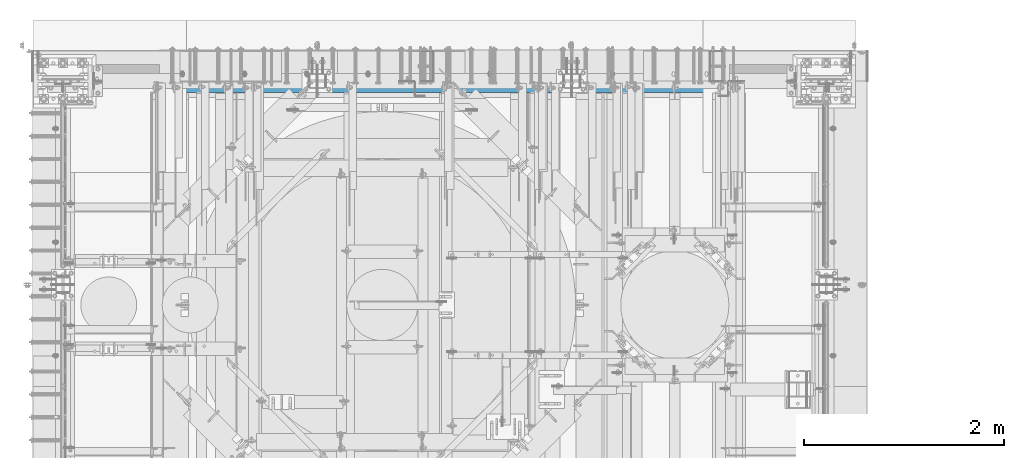
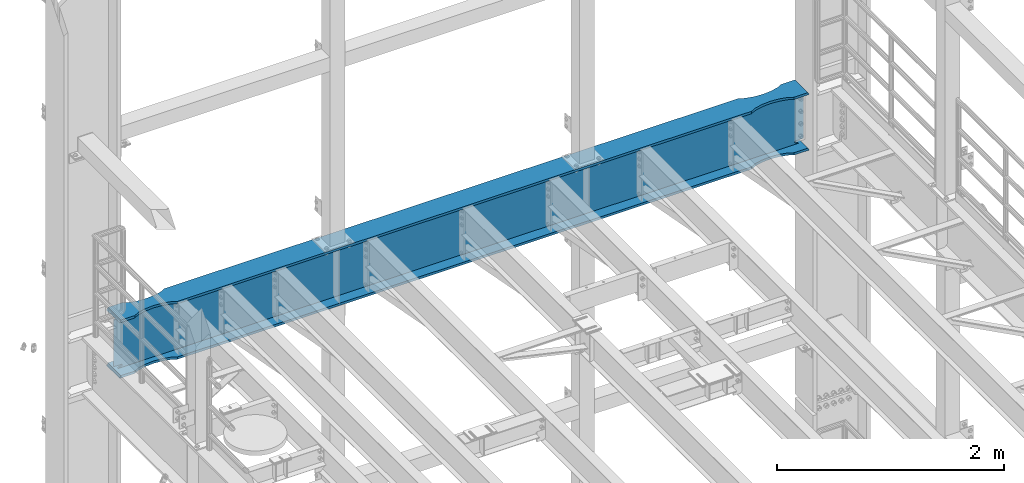
# One storey, part 1065 of 1876: 1 beam, 1 element without a shape of its own.
"""IFC2X3 building model written with IfcOpenShell, lengths in millimetres."""

from ifc_helpers import new_model, si_unit, frame, origin_with_axes, place, context, subcontext, project, spatial, faceted_brep, material, type_object, element, aggregate, save


model = new_model("IFC2X3")

# Units and contexts
model_context = context("Model", 3, precision=1e-05, world=origin_with_axes())
body_context = subcontext(model_context, "Body", "Model", "MODEL_VIEW")
ifc_project = project(units=[si_unit("LENGTHUNIT", "METRE", prefix="MILLI"), si_unit("AREAUNIT", "SQUARE_METRE"), si_unit("VOLUMEUNIT", "CUBIC_METRE"), si_unit("MASSUNIT", "GRAM", prefix="KILO"), si_unit("TIMEUNIT", "SECOND"), si_unit("PLANEANGLEUNIT", "RADIAN"), si_unit("SOLIDANGLEUNIT", "STERADIAN"), si_unit("THERMODYNAMICTEMPERATUREUNIT", "DEGREE_CELSIUS"), si_unit("LUMINOUSINTENSITYUNIT", "LUMEN")], contexts=[model_context])

# Site, building, storey
site_placement = place(None, origin_with_axes())
site = spatial("IfcSite", under=ifc_project, at=site_placement, CompositionType="ELEMENT")
building_placement = place(site_placement, origin_with_axes())
building = spatial("IfcBuilding", under=site, at=building_placement, Name="Undefined", CompositionType="ELEMENT")
storey_placement = place(building_placement, origin_with_axes())
storey = spatial("IfcBuildingStorey", under=building, at=storey_placement, Name="Undefined", CompositionType="ELEMENT", Elevation=0.0)

# Assembly, beam
assembly_placement = place(storey_placement, origin_with_axes())
assembly = element("IfcElementAssembly", 1, at=assembly_placement, inside=storey, Name="BEAM", AssemblyPlace="NOTDEFINED", PredefinedType="RIGID_FRAME")
ifc_material = material(Name="STEEL/A992")
beam_type = type_object("IfcBeamType", Name="W24X103", PredefinedType="NOTDEFINED")
beam_placement = place(assembly_placement, frame((0.0, 13716.0, 17672.05), z_axis=(0.0, 0.0, 1.0), x_axis=(1.0, 0.0, 0.0)))
beam = element("IfcBeam", 2, at=beam_placement, type_object=beam_type, material=ifc_material, Name="BEAM", ObjectType="W24X103", context=body_context, shape_type="Brep", body=[
    faceted_brep([(7310.4375, 7.14374999999927, 250.825000000001), (7318.375, -7.14374999999927, 250.825000000001), (7318.375, -7.14374999999927, -250.825000000001), (7310.4375, 7.14374999999927, -250.825000000001), (301.625, -7.14374999999927, 250.825000000001), (309.5625, 7.14374999999927, 250.825000000001), (309.5625, 7.14374999999927, -250.825000000001), (301.625, -7.14374999999927, -250.825000000001), (7031.26184334843, -69.8863852197028, -285.75), (7031.26184334843, -69.8863852197028, -311.150000000001), (7113.70085269938, -88.8999885500325, -311.150000000001), (7113.70085269938, -88.8999885500325, -285.75), (6946.89999522536, -63.4999969110422, -285.75), (6946.89999522536, -63.4999969110422, -311.150000000001), (6862.53814723751, -69.886387005964, -285.75), (6862.53814723751, -69.886387005964, -311.150000000001), (6780.09913828916, -88.8999920818405, -285.75), (6780.09913828916, -88.8999920818405, -311.150000000001), (6730.99999123786, -114.3, -285.75), (6730.99999123786, -114.3, -311.150000000001), (889.000008761879, -114.300009625518, -285.75), (889.000008761879, -114.3, -311.150000000001), (6730.99999123786, -114.3, 285.75), (6730.99999123786, -114.3, 311.150000000001), (889.000008761879, -114.300009625518, 311.150000000001), (889.000008761879, -114.3, 285.75), (6780.09913828916, -88.8999920818405, 285.75), (6780.09913828916, -88.8999920818405, 311.150000000001), (6862.53814723751, -69.886387005964, 285.75), (6862.53814723751, -69.886387005964, 311.150000000001), (6946.89999522536, -63.4999969110422, 285.75), (6946.89999522536, -63.4999969110422, 311.150000000001), (7031.26184334843, -69.8863852197028, 285.75), (7031.26184334843, -69.8863852197028, 311.150000000001), (7113.70085269938, -88.8999885500325, 285.75), (7113.70085269938, -88.8999885500325, 311.150000000001), (7162.79999999982, -114.299985144468, 311.150000000001), (7162.79999999982, -114.3, 285.75), (7318.375, -114.3, 285.75), (7303.71041369173, -114.299998599709, 311.150000000001), (7269.91500317383, -7.14375000000018, -285.35299987793), (7269.91500317383, 7.14375000000018, -285.35299987793), (7234.44274885072, 7.14375000000018, -269.000062630286), (7234.44274885072, -7.14375000000018, -269.000062630286), (7230.55254094452, 7.14375000000018, -265.703842989446), (7230.55254094452, -7.14375000000018, -265.703842989446), (7228.91987519741, 7.14375000000018, -260.873399528195), (7228.91987519741, -7.14375000000018, -260.873399528195), (7230.01261637614, 7.14375000000018, -255.89296800167), (7230.01261637614, -7.14375000000018, -255.89296800167), (7233.51762316711, 7.14375000000018, -252.189765486371), (7233.51762316711, -7.14375000000018, -252.189765486371), (7238.43048349907, 7.14375000000018, -250.825000000001), (7238.43048349907, -7.14375000000018, -250.825000000001), (7239.26548546451, 7.14375000000018, 250.825000000001), (7239.26548546451, -7.14375000000018, 250.825000000001), (7234.35262519576, 7.14375000000018, 252.189765448315), (7234.35262519576, -7.14375000000018, 252.189765448315), (7230.84761841062, 7.14375000000018, 255.892967871263), (7230.84761841062, -7.14375000000018, 255.892967871263), (7229.75487715069, 7.14375000000018, 260.873399307191), (7229.75487715069, -7.14375000000018, 260.873399307191), (7231.38754274408, 7.14375000000018, 265.703842745359), (7231.38754274408, -7.14375000000018, 265.703842745359), (7235.27775048114, 7.14375000000018, 269.000062475843), (7235.27775048114, -7.14375000000018, 269.000062475843), (7270.75000152588, 7.14375000000018, 285.35299987793), (7270.75000152588, -7.14375000000018, 285.35299987793), (7318.375, 7.14375000000018, 285.35299987793), (7318.375, -7.14375000000018, 285.35299987793), (7318.375, 7.14375000000018, 285.75), (7318.375, -7.14375000000018, 285.75), (6730.99999123786, 114.3, 311.150000000001), (6730.99999123786, 114.3, 285.75), (889.000008761879, 114.3, 285.75), (889.000008761879, 114.299990374482, 311.150000000001), (6780.09913828916, 88.9000064541397, 311.150000000001), (6780.09913828916, 88.9000064541397, 285.75), (6862.53814723751, 69.8864013782631, 311.150000000001), (6862.53814723751, 69.8864013782631, 285.75), (6946.89999522536, 63.5000112833413, 311.150000000001), (6946.89999522536, 63.5000112833413, 285.75), (7031.26184334843, 69.8863995920019, 311.150000000001), (7031.26184334843, 69.8863995920019, 285.75), (7113.70085269938, 88.9000029223316, 311.150000000001), (7113.70085269938, 88.9000029223316, 285.75), (7162.79999999982, 114.299999516767, 311.150000000001), (7162.79999999982, 114.3, 285.75), (7303.71041369173, 114.29999995445, 311.150000000001), (7318.375, 114.3, 285.75), (301.625, 7.14375000000018, 285.75), (301.625, 114.3, 285.75), (457.200000000009, 114.3, 285.75), (506.299147300449, 88.899986110664, 285.75), (588.738156651386, 69.8863827803343, 285.75), (673.100004774441, 63.4999944716737, 285.75), (757.461852762268, 69.8863845665956, 285.75), (839.9008617106, 88.8999896424721, 285.75), (457.200000000009, 114.3, 311.150000000001), (316.289586308271, 114.3, 311.150000000001), (506.299147300449, 88.899986110664, 311.150000000001), (588.738156651386, 69.8863827803343, 311.150000000001), (673.100004774441, 63.4999944716737, 311.150000000001), (757.461852762268, 69.8863845665956, 311.150000000001), (839.9008617106, 88.8999896424721, 311.150000000001), (316.289586308271, -114.3, 311.150000000001), (457.200000000009, -114.3, 311.150000000001), (506.299147300449, -88.9000053617001, 311.150000000001), (588.738156651386, -69.8864020313704, 311.150000000001), (673.100004774441, -63.5000137227098, 311.150000000001), (757.461852762268, -69.8864038176316, 311.150000000001), (839.9008617106, -88.9000088935081, 311.150000000001), (457.200000000009, -114.3, 285.75), (301.625, -114.3, 285.75), (506.299147300449, -88.9000053617001, 285.75), (588.738156651386, -69.8864020313704, 285.75), (673.100004774441, -63.5000137227098, 285.75), (757.461852762268, -69.8864038176316, 285.75), (839.9008617106, -88.9000088935081, 285.75), (301.625, -7.14375000000018, 285.75), (301.625, 7.14375000000018, 285.35299987793), (301.625, -7.14375000000018, 285.35299987793), (349.249998474121, 7.14375000000018, 285.35299987793), (349.249998474121, -7.14375000000018, 285.35299987793), (384.722249518856, 7.14375000000018, 269.000062475843), (384.722249518856, -7.14375000000018, 269.000062475843), (388.612457255921, 7.14375000000018, 265.703842745359), (388.612457255921, -7.14375000000018, 265.703842745359), (390.245122849314, 7.14375000000018, 260.873399307191), (390.245122849314, -7.14375000000018, 260.873399307191), (389.152381589376, 7.14375000000018, 255.892967871263), (389.152381589376, -7.14375000000018, 255.892967871263), (385.647374804242, 7.14375000000018, 252.189765448315), (385.647374804242, -7.14375000000018, 252.189765448315), (380.734514535493, 7.14375000000018, 250.825000000001), (380.734514535493, -7.14375000000018, 250.825000000001), (381.56951650093, 7.14375000000018, -250.825000000001), (381.56951650093, -7.14375000000018, -250.825000000001), (386.482376832887, 7.14375000000018, -252.189765486371), (386.482376832887, -7.14375000000018, -252.189765486371), (389.98738362386, 7.14375000000018, -255.89296800167), (389.98738362386, -7.14375000000018, -255.89296800167), (391.080124802588, 7.14375000000018, -260.873399528195), (391.080124802588, -7.14375000000018, -260.873399528195), (389.447459055476, 7.14375000000018, -265.703842989446), (389.447459055476, -7.14375000000018, -265.703842989446), (385.557251149282, 7.14375000000018, -269.000062630286), (385.557251149282, -7.14375000000018, -269.000062630286), (350.084996826172, 7.14375000000018, -285.35299987793), (350.084996826172, -7.14375000000018, -285.35299987793), (316.518799385621, 7.14375000000018, -285.35299987793), (316.518799385621, -7.14375000000018, -285.35299987793), (316.28959905754, -7.14375000000018, -285.75), (7303.71040094246, -7.14375000000018, -285.75), (7303.48120061438, -7.14375000000018, -285.35299987793), (7303.48120061438, 7.14375000000018, -285.35299987793), (7303.71040094246, 7.14375000000018, -285.75), (316.28959905754, 7.14375000000018, -285.75), (316.28959905754, 114.3, -285.75), (301.625, 114.3, -311.150000000001), (301.625, -114.3, -311.150000000001), (316.28959905754, -114.3, -285.75), (457.200000000009, -114.3, -311.150000000001), (457.200000000009, -114.3, -285.75), (506.299147300449, -88.9000053617001, -311.150000000001), (506.299147300449, -88.9000053617001, -285.75), (588.738156651386, -69.8864020313704, -311.150000000001), (588.738156651386, -69.8864020313704, -285.75), (673.100004774441, -63.5000137227098, -311.150000000001), (673.100004774441, -63.5000137227098, -285.75), (757.461852762268, -69.8864038176316, -311.150000000001), (757.461852762268, -69.8864038176316, -285.75), (839.9008617106, -88.9000088935081, -311.150000000001), (839.9008617106, -88.9000088935081, -285.75), (7162.79999999982, -114.299985144468, -285.75), (7303.71040094246, -114.299998599708, -285.75), (7318.375, -114.3, -311.150000000001), (7318.375, 114.3, -311.150000000001), (7303.71040094246, 114.29999995445, -285.75), (7162.79999999982, 114.3, -311.150000000001), (7162.79999999982, 114.299999516767, -285.75), (7113.70085269938, 88.9000029223316, -311.150000000001), (7113.70085269938, 88.9000029223316, -285.75), (7031.26184334843, 69.8863995920019, -311.150000000001), (7031.26184334843, 69.8863995920019, -285.75), (6946.89999522536, 63.5000112833413, -311.150000000001), (6946.89999522536, 63.5000112833413, -285.75), (6862.53814723751, 69.8864013782631, -311.150000000001), (6862.53814723751, 69.8864013782631, -285.75), (6780.09913828916, 88.9000064541397, -311.150000000001), (6780.09913828916, 88.9000064541397, -285.75), (6730.99999123786, 114.3, -311.150000000001), (6730.99999123786, 114.3, -285.75), (889.000008761879, 114.3, -311.150000000001), (889.000008761879, 114.299990374482, -285.75), (839.9008617106, 88.8999896424721, -285.75), (757.461852762268, 69.8863845665956, -285.75), (673.100004774441, 63.4999944716737, -285.75), (588.738156651386, 69.8863827803343, -285.75), (506.299147300449, 88.899986110664, -285.75), (457.200000000009, 114.3, -285.75), (457.200000000009, 114.3, -311.150000000001), (506.299147300449, 88.899986110664, -311.150000000001), (588.738156651386, 69.8863827803343, -311.150000000001), (673.100004774441, 63.4999944716737, -311.150000000001), (757.461852762268, 69.8863845665956, -311.150000000001), (839.9008617106, 88.8999896424721, -311.150000000001), (7162.79999999982, -114.3, -311.150000000001)], [[[0, 1, 2, 3]], [[4, 5, 6, 7]], [[8, 9, 10, 11]], [[12, 13, 9, 8]], [[14, 15, 13, 12]], [[16, 17, 15, 14]], [[18, 19, 17, 16]], [[19, 18, 20, 21]], [[22, 23, 24, 25]], [[23, 22, 26, 27]], [[27, 26, 28, 29]], [[29, 28, 30, 31]], [[31, 30, 32, 33]], [[33, 32, 34, 35]], [[36, 35, 34, 37]], [[36, 37, 38, 39]], [[40, 41, 42, 43]], [[43, 42, 44, 45]], [[45, 44, 46, 47]], [[47, 46, 48, 49]], [[49, 48, 50, 51]], [[51, 50, 52, 53]], [[53, 52, 3, 2]], [[54, 55, 1, 0]], [[55, 54, 56, 57]], [[57, 56, 58, 59]], [[59, 58, 60, 61]], [[61, 60, 62, 63]], [[63, 62, 64, 65]], [[65, 64, 66, 67]], [[67, 66, 68, 69]], [[69, 68, 70, 71]], [[72, 73, 74, 75]], [[76, 77, 73, 72]], [[78, 79, 77, 76]], [[80, 81, 79, 78]], [[82, 83, 81, 80]], [[84, 85, 83, 82]], [[86, 87, 85, 84]], [[87, 86, 88, 89]], [[38, 71, 70, 89, 88, 39]], [[90, 91, 92, 93, 94, 95, 96, 97, 74, 73, 77, 79, 81, 83, 85, 87, 89, 70]], [[98, 92, 91, 99]], [[100, 93, 92, 98]], [[101, 94, 93, 100]], [[102, 95, 94, 101]], [[103, 96, 95, 102]], [[104, 97, 96, 103]], [[75, 74, 97, 104]], [[86, 84, 82, 80, 78, 76, 72, 75, 104, 103, 102, 101, 100, 98, 99, 105, 106, 107, 108, 109, 110, 111, 24, 23, 27, 29, 31, 33, 35, 36, 39, 88]], [[112, 106, 105, 113]], [[106, 112, 114, 107]], [[107, 114, 115, 108]], [[108, 115, 116, 109]], [[109, 116, 117, 110]], [[110, 117, 118, 111]], [[24, 111, 118, 25]], [[37, 34, 32, 30, 28, 26, 22, 25, 118, 117, 116, 115, 114, 112, 113, 119, 71, 38]], [[105, 99, 91, 90, 119, 113]], [[120, 121, 119, 90]], [[122, 123, 121, 120]], [[123, 122, 124, 125]], [[125, 124, 126, 127]], [[127, 126, 128, 129]], [[129, 128, 130, 131]], [[131, 130, 132, 133]], [[133, 132, 134, 135]], [[135, 134, 5, 4]], [[136, 137, 7, 6]], [[137, 136, 138, 139]], [[139, 138, 140, 141]], [[141, 140, 142, 143]], [[143, 142, 144, 145]], [[145, 144, 146, 147]], [[147, 146, 148, 149]], [[149, 148, 150, 151]], [[40, 43, 45, 47, 49, 51, 53, 2, 1, 55, 57, 59, 61, 63, 65, 67, 69, 71, 119, 121, 123, 125, 127, 129, 131, 133, 135, 4, 7, 137, 139, 141, 143, 145, 147, 149, 151, 152, 153, 154]], [[41, 40, 154, 155]], [[52, 50, 48, 46, 44, 42, 41, 155, 156, 157, 150, 148, 146, 144, 142, 140, 138, 136, 6, 5, 134, 132, 130, 128, 126, 124, 122, 120, 90, 70, 68, 66, 64, 62, 60, 58, 56, 54, 0, 3]], [[151, 150, 157, 158, 159, 160, 161, 152]], [[162, 163, 161, 160]], [[163, 162, 164, 165]], [[165, 164, 166, 167]], [[167, 166, 168, 169]], [[169, 168, 170, 171]], [[171, 170, 172, 173]], [[20, 173, 172, 21]], [[152, 161, 163, 165, 167, 169, 171, 173, 20, 18, 16, 14, 12, 8, 11, 174, 175, 153]], [[176, 177, 178, 156, 155, 154, 153, 175]], [[179, 180, 178, 177]], [[180, 179, 181, 182]], [[182, 181, 183, 184]], [[184, 183, 185, 186]], [[186, 185, 187, 188]], [[188, 187, 189, 190]], [[190, 189, 191, 192]], [[192, 191, 193, 194]], [[180, 182, 184, 186, 188, 190, 192, 194, 195, 196, 197, 198, 199, 200, 158, 157, 156, 178]], [[200, 201, 159, 158]], [[199, 202, 201, 200]], [[198, 203, 202, 199]], [[197, 204, 203, 198]], [[196, 205, 204, 197]], [[195, 206, 205, 196]], [[194, 193, 206, 195]], [[207, 10, 9, 13, 15, 17, 19, 21, 172, 170, 168, 166, 164, 162, 160, 159, 201, 202, 203, 204, 205, 206, 193, 191, 189, 187, 185, 183, 181, 179, 177, 176]], [[174, 11, 10, 207]], [[174, 207, 176, 175]]]),
])
aggregate(assembly, [beam])

save(model, "model.ifc")
